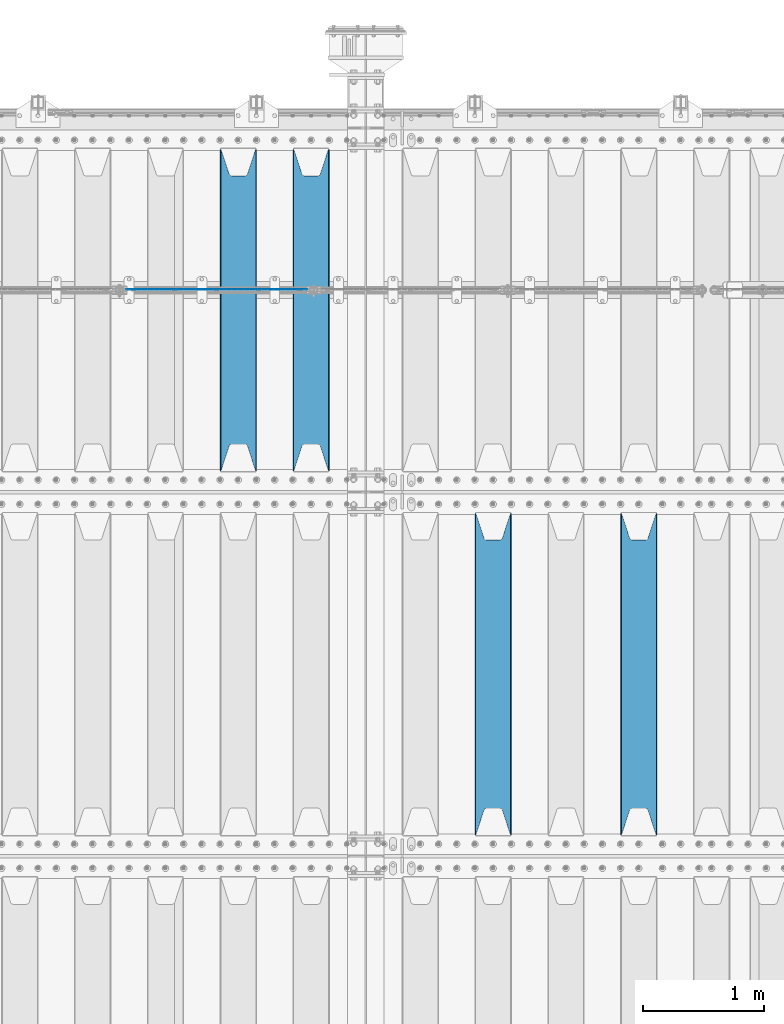
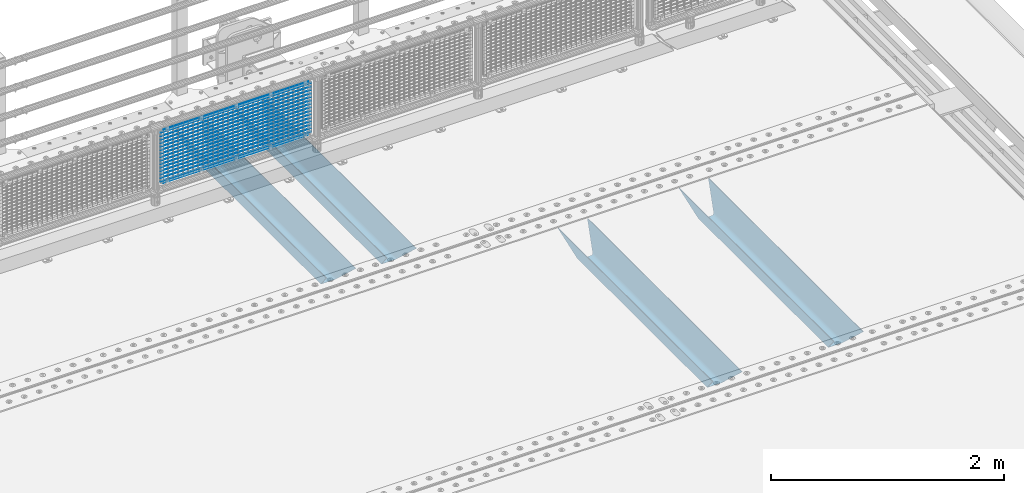
# One storey, part 125 of 257: 21 beams.
"""IFC2X3 building model written with IfcOpenShell, lengths in millimetres."""

from ifc_helpers import new_model, si_unit, frame, origin_with_axes, place, context, subcontext, project, spatial, faceted_brep, material, type_object, element, save


model = new_model("IFC2X3")

# Units and contexts
model_context = context("Model", 3, precision=1e-05, world=origin_with_axes())
body_context = subcontext(model_context, "Body", "Model", "MODEL_VIEW")
ifc_project = project(units=[si_unit("LENGTHUNIT", "METRE", prefix="MILLI"), si_unit("AREAUNIT", "SQUARE_METRE"), si_unit("VOLUMEUNIT", "CUBIC_METRE"), si_unit("MASSUNIT", "GRAM", prefix="KILO"), si_unit("TIMEUNIT", "SECOND"), si_unit("PLANEANGLEUNIT", "RADIAN"), si_unit("SOLIDANGLEUNIT", "STERADIAN"), si_unit("THERMODYNAMICTEMPERATUREUNIT", "DEGREE_CELSIUS"), si_unit("LUMINOUSINTENSITYUNIT", "LUMEN")], contexts=[model_context])

# Site, building, storey
site_placement = place(None, origin_with_axes())
site = spatial("IfcSite", under=ifc_project, at=site_placement, CompositionType="ELEMENT")
building_placement = place(site_placement, origin_with_axes())
building = spatial("IfcBuilding", under=site, at=building_placement, Name="Standard", CompositionType="ELEMENT")
storey_placement = place(building_placement, origin_with_axes())
storey = spatial("IfcBuildingStorey", under=building, at=storey_placement, Name="Undefined", CompositionType="ELEMENT", Elevation=0.0)

# Beams
ifc_material_1 = material(Name="STEEL/S355N")
beam_type_1 = type_object("IfcBeamType", PredefinedType="NOTDEFINED")
beam_1_placement = place(storey_placement, frame((56950.0, 6175.0, -115.0), z_axis=(0.0, 0.0, 1.0), x_axis=(0.0, 1.0, 0.0)))
element("IfcBeam", 1, at=beam_1_placement, inside=storey, type_object=beam_type_1, material=ifc_material_1, context=body_context, shape_type="Brep", body=[
    faceted_brep([(0.0, 150.0, 115.0), (0.0, 143.690000000002, 115.0), (2650.00000000297, 143.690000000002, 115.0), (2650.00000000297, 150.0, 115.0), (2650.00000000297, 142.059565218406, 110.0000000031), (2650.00000000297, 148.369565218403, 110.0000000031), (2441.90079219208, -80.1103600731149, -98.0992078077845), (2437.7588105432, -77.5672621345584, -102.241189456673), (2434.06523489746, -74.4080125315522, -105.934765102404), (2430.91086095089, -70.7102721255724, -109.089139048974), (2428.37322971128, -66.5649389910031, -111.626770288588), (2426.51472138055, -62.0739139532889, -113.485278619323), (2425.38102192091, -57.3475956567636, -114.618978078955), (2424.99999999987, -52.5021667386536, -115.0), (2424.99999999987, 52.5021667386536, -115.0), (2425.38102192091, 57.3475956567636, -114.618978078955), (2426.51472138055, 62.0739139532889, -113.485278619323), (2428.37322971128, 66.5649389910031, -111.626770288588), (2430.91086095089, 70.7102721255724, -109.089139048974), (2434.06523489746, 74.4080125315522, -105.934765102404), (2437.7588105432, 77.5672621345584, -102.241189456673), (2441.90079219208, 80.1103600731149, -98.0992078077846), (2446.38936140511, 81.9747917625791, -93.6106385947584), (2448.24948500409, 76.2713538057287, -91.7505149957729), (2444.62967112262, 74.76777986261, -95.3703288772456), (2441.28936334126, 72.7168944282894, -98.710636658607), (2438.31067330438, 70.1691124903809, -101.689326695487), (2435.76682334747, 67.1870637758839, -104.233176652398), (2433.72034654133, 63.8440531834931, -106.279653458539), (2432.22154950041, 60.2222587982324, -107.778450499454), (2431.30727574265, 56.4107117849126, -108.692724257221), (2430.99999999987, 52.5031078186876, -109.0), (2430.99999999987, -52.5031078186876, -109.0), (2431.30727574265, -56.4107117849126, -108.692724257221), (2432.22154950041, -60.2222587982324, -107.778450499454), (2433.72034654133, -63.8440531834931, -106.279653458539), (2435.76682334747, -67.1870637758839, -104.233176652398), (2438.31067330438, -70.1691124903809, -101.689326695487), (2441.28936334126, -72.7168944282894, -98.7106366586071), (2444.62967112262, -74.76777986261, -95.3703288772457), (2448.24948500409, -76.2713538057287, -91.7505149957729), (2650.00000000297, -142.059565218406, 110.0000000031), (2650.00000000297, -148.369565218403, 110.0000000031), (2446.38936140511, -81.9747917625791, -93.6106385947584), (2650.00000000297, -143.690000000002, 115.0), (2650.00000000297, -150.0, 115.0), (0.0, -143.690000000002, 115.0), (0.0, -150.0, 115.0), (0.0, -148.369565218258, 110.000000002662), (203.61063859742, -81.9747917625791, -93.6106385947584), (208.099207810447, -80.1103600731149, -98.0992078077845), (212.241189459335, -77.5672621345584, -102.241189456673), (215.934765105066, -74.4080125315522, -105.934765102404), (219.089139051636, -70.7102721255724, -109.089139048974), (221.626770291251, -66.5649389910031, -111.626770288588), (223.485278621985, -62.0739139532889, -113.485278619323), (224.618978081617, -57.3475956567636, -114.618978078955), (225.000000002662, -52.5021667386536, -115.0), (225.000000002662, 52.5021667386536, -115.0), (224.618978081617, 57.3475956567636, -114.618978078955), (223.485278621985, 62.0739139532889, -113.485278619323), (221.626770291251, 66.5649389910031, -111.626770288588), (219.089139051636, 70.7102721255724, -109.089139048974), (215.934765105066, 74.4080125315522, -105.934765102404), (212.241189459335, 77.5672621345584, -102.241189456673), (208.099207810447, 80.1103600731149, -98.0992078077846), (203.61063859742, 81.9747917625791, -93.6106385947584), (0.0, 148.369565218258, 110.000000002662), (0.0, 142.05956521826, 110.000000002662), (201.750514998435, 76.2713538057287, -91.7505149957729), (205.370328879908, 74.76777986261, -95.3703288772456), (208.710636661269, 72.7168944282894, -98.710636658607), (211.689326698149, 70.1691124903809, -101.689326695487), (214.233176655061, 67.1870637758839, -104.233176652398), (216.279653461201, 63.8440531834931, -106.279653458539), (217.778450502116, 60.2222587982324, -107.778450499454), (218.692724259884, 56.4107117849126, -108.692724257221), (219.000000002662, 52.5031078186876, -109.0), (219.000000002662, -52.5031078186876, -109.0), (218.692724259884, -56.4107117849126, -108.692724257221), (217.778450502116, -60.2222587982324, -107.778450499454), (216.279653461201, -63.8440531834931, -106.279653458539), (214.233176655061, -67.1870637758839, -104.233176652398), (211.689326698149, -70.1691124903809, -101.689326695487), (208.710636661269, -72.7168944282894, -98.7106366586071), (205.370328879908, -74.76777986261, -95.3703288772457), (201.750514998435, -76.2713538057287, -91.7505149957729), (0.0, -142.05956521826, 110.000000002662)], [[[0, 1, 2, 3]], [[3, 2, 4, 5]], [[6, 7, 8, 9, 10, 11, 12, 13, 14, 15, 16, 17, 18, 19, 20, 21, 22, 5, 4, 23, 24, 25, 26, 27, 28, 29, 30, 31, 32, 33, 34, 35, 36, 37, 38, 39, 40, 41, 42, 43]], [[44, 45, 42, 41]], [[46, 47, 45, 44]], [[43, 42, 45, 47, 48, 49]], [[6, 43, 49, 50]], [[7, 6, 50, 51]], [[8, 7, 51, 52]], [[9, 8, 52, 53]], [[10, 9, 53, 54]], [[11, 10, 54, 55]], [[12, 11, 55, 56]], [[13, 12, 56, 57]], [[14, 13, 57, 58]], [[15, 14, 58, 59]], [[16, 15, 59, 60]], [[17, 16, 60, 61]], [[18, 17, 61, 62]], [[19, 18, 62, 63]], [[20, 19, 63, 64]], [[21, 20, 64, 65]], [[22, 21, 65, 66]], [[0, 3, 5, 22, 66, 67]], [[1, 0, 67, 68]], [[23, 4, 2, 1, 68, 69]], [[24, 23, 69, 70]], [[25, 24, 70, 71]], [[26, 25, 71, 72]], [[27, 26, 72, 73]], [[28, 27, 73, 74]], [[29, 28, 74, 75]], [[30, 29, 75, 76]], [[31, 30, 76, 77]], [[32, 31, 77, 78]], [[33, 32, 78, 79]], [[34, 33, 79, 80]], [[35, 34, 80, 81]], [[36, 35, 81, 82]], [[37, 36, 82, 83]], [[38, 37, 83, 84]], [[39, 38, 84, 85]], [[40, 39, 85, 86]], [[46, 44, 41, 40, 86, 87]], [[47, 46, 87, 48]], [[86, 85, 84, 83, 82, 81, 80, 79, 78, 77, 76, 75, 74, 73, 72, 71, 70, 69, 68, 67, 66, 65, 64, 63, 62, 61, 60, 59, 58, 57, 56, 55, 54, 53, 52, 51, 50, 49, 48, 87]]]),
])
beam_2_placement = place(storey_placement, frame((55750.0, 6175.0, -115.0), z_axis=(0.0, 0.0, 1.0), x_axis=(0.0, 1.0, 0.0)))
element("IfcBeam", 2, at=beam_2_placement, inside=storey, type_object=beam_type_1, material=ifc_material_1, context=body_context, shape_type="Brep", body=[
    faceted_brep([(0.0, 150.0, 115.0), (0.0, 143.690000000002, 115.0), (2650.00000000297, 143.690000000002, 115.0), (2650.00000000297, 150.0, 115.0), (2650.00000000297, 142.059565218406, 110.0000000031), (2650.00000000297, 148.369565218403, 110.0000000031), (2441.90079219208, -80.1103600731149, -98.0992078077845), (2437.7588105432, -77.5672621345584, -102.241189456673), (2434.06523489746, -74.4080125315522, -105.934765102404), (2430.91086095089, -70.7102721255724, -109.089139048974), (2428.37322971128, -66.5649389910031, -111.626770288588), (2426.51472138055, -62.0739139532889, -113.485278619323), (2425.38102192091, -57.3475956567636, -114.618978078955), (2424.99999999987, -52.5021667386536, -115.0), (2424.99999999987, 52.5021667386536, -115.0), (2425.38102192091, 57.3475956567636, -114.618978078955), (2426.51472138055, 62.0739139532889, -113.485278619323), (2428.37322971128, 66.5649389910031, -111.626770288588), (2430.91086095089, 70.7102721255724, -109.089139048974), (2434.06523489746, 74.4080125315522, -105.934765102404), (2437.7588105432, 77.5672621345584, -102.241189456673), (2441.90079219208, 80.1103600731149, -98.0992078077846), (2446.38936140511, 81.9747917625791, -93.6106385947584), (2448.24948500409, 76.2713538057287, -91.7505149957729), (2444.62967112262, 74.76777986261, -95.3703288772456), (2441.28936334126, 72.7168944282894, -98.710636658607), (2438.31067330438, 70.1691124903809, -101.689326695487), (2435.76682334747, 67.1870637758839, -104.233176652398), (2433.72034654133, 63.8440531834931, -106.279653458539), (2432.22154950041, 60.2222587982324, -107.778450499454), (2431.30727574265, 56.4107117849126, -108.692724257221), (2430.99999999987, 52.5031078186876, -109.0), (2430.99999999987, -52.5031078186876, -109.0), (2431.30727574265, -56.4107117849126, -108.692724257221), (2432.22154950041, -60.2222587982324, -107.778450499454), (2433.72034654133, -63.8440531834931, -106.279653458539), (2435.76682334747, -67.1870637758839, -104.233176652398), (2438.31067330438, -70.1691124903809, -101.689326695487), (2441.28936334126, -72.7168944282894, -98.7106366586071), (2444.62967112262, -74.76777986261, -95.3703288772457), (2448.24948500409, -76.2713538057287, -91.7505149957729), (2650.00000000297, -142.059565218406, 110.0000000031), (2650.00000000297, -148.369565218403, 110.0000000031), (2446.38936140511, -81.9747917625791, -93.6106385947584), (2650.00000000297, -143.690000000002, 115.0), (2650.00000000297, -150.0, 115.0), (0.0, -143.690000000002, 115.0), (0.0, -150.0, 115.0), (0.0, -148.369565218258, 110.000000002662), (203.61063859742, -81.9747917625791, -93.6106385947584), (208.099207810447, -80.1103600731149, -98.0992078077845), (212.241189459335, -77.5672621345584, -102.241189456673), (215.934765105066, -74.4080125315522, -105.934765102404), (219.089139051636, -70.7102721255724, -109.089139048974), (221.626770291251, -66.5649389910031, -111.626770288588), (223.485278621985, -62.0739139532889, -113.485278619323), (224.618978081617, -57.3475956567636, -114.618978078955), (225.000000002662, -52.5021667386536, -115.0), (225.000000002662, 52.5021667386536, -115.0), (224.618978081617, 57.3475956567636, -114.618978078955), (223.485278621985, 62.0739139532889, -113.485278619323), (221.626770291251, 66.5649389910031, -111.626770288588), (219.089139051636, 70.7102721255724, -109.089139048974), (215.934765105066, 74.4080125315522, -105.934765102404), (212.241189459335, 77.5672621345584, -102.241189456673), (208.099207810447, 80.1103600731149, -98.0992078077846), (203.61063859742, 81.9747917625791, -93.6106385947584), (0.0, 148.369565218258, 110.000000002662), (0.0, 142.05956521826, 110.000000002662), (201.750514998435, 76.2713538057287, -91.7505149957729), (205.370328879908, 74.76777986261, -95.3703288772456), (208.710636661269, 72.7168944282894, -98.710636658607), (211.689326698149, 70.1691124903809, -101.689326695487), (214.233176655061, 67.1870637758839, -104.233176652398), (216.279653461201, 63.8440531834931, -106.279653458539), (217.778450502116, 60.2222587982324, -107.778450499454), (218.692724259884, 56.4107117849126, -108.692724257221), (219.000000002662, 52.5031078186876, -109.0), (219.000000002662, -52.5031078186876, -109.0), (218.692724259884, -56.4107117849126, -108.692724257221), (217.778450502116, -60.2222587982324, -107.778450499454), (216.279653461201, -63.8440531834931, -106.279653458539), (214.233176655061, -67.1870637758839, -104.233176652398), (211.689326698149, -70.1691124903809, -101.689326695487), (208.710636661269, -72.7168944282894, -98.7106366586071), (205.370328879908, -74.76777986261, -95.3703288772457), (201.750514998435, -76.2713538057287, -91.7505149957729), (0.0, -142.05956521826, 110.000000002662)], [[[0, 1, 2, 3]], [[3, 2, 4, 5]], [[6, 7, 8, 9, 10, 11, 12, 13, 14, 15, 16, 17, 18, 19, 20, 21, 22, 5, 4, 23, 24, 25, 26, 27, 28, 29, 30, 31, 32, 33, 34, 35, 36, 37, 38, 39, 40, 41, 42, 43]], [[44, 45, 42, 41]], [[46, 47, 45, 44]], [[43, 42, 45, 47, 48, 49]], [[6, 43, 49, 50]], [[7, 6, 50, 51]], [[8, 7, 51, 52]], [[9, 8, 52, 53]], [[10, 9, 53, 54]], [[11, 10, 54, 55]], [[12, 11, 55, 56]], [[13, 12, 56, 57]], [[14, 13, 57, 58]], [[15, 14, 58, 59]], [[16, 15, 59, 60]], [[17, 16, 60, 61]], [[18, 17, 61, 62]], [[19, 18, 62, 63]], [[20, 19, 63, 64]], [[21, 20, 64, 65]], [[22, 21, 65, 66]], [[0, 3, 5, 22, 66, 67]], [[1, 0, 67, 68]], [[23, 4, 2, 1, 68, 69]], [[24, 23, 69, 70]], [[25, 24, 70, 71]], [[26, 25, 71, 72]], [[27, 26, 72, 73]], [[28, 27, 73, 74]], [[29, 28, 74, 75]], [[30, 29, 75, 76]], [[31, 30, 76, 77]], [[32, 31, 77, 78]], [[33, 32, 78, 79]], [[34, 33, 79, 80]], [[35, 34, 80, 81]], [[36, 35, 81, 82]], [[37, 36, 82, 83]], [[38, 37, 83, 84]], [[39, 38, 84, 85]], [[40, 39, 85, 86]], [[46, 44, 41, 40, 86, 87]], [[47, 46, 87, 48]], [[86, 85, 84, 83, 82, 81, 80, 79, 78, 77, 76, 75, 74, 73, 72, 71, 70, 69, 68, 67, 66, 65, 64, 63, 62, 61, 60, 59, 58, 57, 56, 55, 54, 53, 52, 51, 50, 49, 48, 87]]]),
])
beam_3_placement = place(storey_placement, frame((54250.0, 9175.0, -115.0), z_axis=(0.0, 0.0, 1.0), x_axis=(0.0, 1.0, 0.0)))
element("IfcBeam", 3, at=beam_3_placement, inside=storey, type_object=beam_type_1, material=ifc_material_1, context=body_context, shape_type="Brep", body=[
    faceted_brep([(0.0, 150.0, 115.0), (0.0, 143.690000000002, 115.0), (2650.00000000297, 143.690000000002, 115.0), (2650.00000000297, 150.0, 115.0), (2650.00000000297, 142.059565218406, 110.0000000031), (2650.00000000297, 148.369565218403, 110.0000000031), (2441.90079219208, -80.1103600731149, -98.0992078077845), (2437.7588105432, -77.5672621345584, -102.241189456673), (2434.06523489746, -74.4080125315522, -105.934765102404), (2430.91086095089, -70.7102721255724, -109.089139048974), (2428.37322971128, -66.5649389910031, -111.626770288588), (2426.51472138055, -62.0739139532889, -113.485278619323), (2425.38102192091, -57.3475956567636, -114.618978078955), (2424.99999999987, -52.5021667386536, -115.0), (2424.99999999987, 52.5021667386536, -115.0), (2425.38102192091, 57.3475956567636, -114.618978078955), (2426.51472138055, 62.0739139532889, -113.485278619323), (2428.37322971128, 66.5649389910031, -111.626770288588), (2430.91086095089, 70.7102721255724, -109.089139048974), (2434.06523489746, 74.4080125315522, -105.934765102404), (2437.7588105432, 77.5672621345584, -102.241189456673), (2441.90079219208, 80.1103600731149, -98.0992078077846), (2446.38936140511, 81.9747917625791, -93.6106385947584), (2448.24948500409, 76.2713538057287, -91.7505149957729), (2444.62967112262, 74.76777986261, -95.3703288772456), (2441.28936334126, 72.7168944282894, -98.710636658607), (2438.31067330438, 70.1691124903809, -101.689326695487), (2435.76682334747, 67.1870637758839, -104.233176652398), (2433.72034654133, 63.8440531834931, -106.279653458539), (2432.22154950041, 60.2222587982324, -107.778450499454), (2431.30727574265, 56.4107117849126, -108.692724257221), (2430.99999999987, 52.5031078186876, -109.0), (2430.99999999987, -52.5031078186876, -109.0), (2431.30727574265, -56.4107117849126, -108.692724257221), (2432.22154950041, -60.2222587982324, -107.778450499454), (2433.72034654133, -63.8440531834931, -106.279653458539), (2435.76682334747, -67.1870637758839, -104.233176652398), (2438.31067330438, -70.1691124903809, -101.689326695487), (2441.28936334126, -72.7168944282894, -98.7106366586071), (2444.62967112262, -74.76777986261, -95.3703288772457), (2448.24948500409, -76.2713538057287, -91.7505149957729), (2650.00000000297, -142.059565218406, 110.0000000031), (2650.00000000297, -148.369565218403, 110.0000000031), (2446.38936140511, -81.9747917625791, -93.6106385947584), (2650.00000000297, -143.690000000002, 115.0), (2650.00000000297, -150.0, 115.0), (0.0, -143.690000000002, 115.0), (0.0, -150.0, 115.0), (0.0, -148.369565218258, 110.000000002662), (203.61063859742, -81.9747917625791, -93.6106385947584), (208.099207810447, -80.1103600731149, -98.0992078077845), (212.241189459335, -77.5672621345584, -102.241189456673), (215.934765105066, -74.4080125315522, -105.934765102404), (219.089139051636, -70.7102721255724, -109.089139048974), (221.626770291251, -66.5649389910031, -111.626770288588), (223.485278621985, -62.0739139532889, -113.485278619323), (224.618978081617, -57.3475956567636, -114.618978078955), (225.000000002662, -52.5021667386536, -115.0), (225.000000002662, 52.5021667386536, -115.0), (224.618978081617, 57.3475956567636, -114.618978078955), (223.485278621985, 62.0739139532889, -113.485278619323), (221.626770291251, 66.5649389910031, -111.626770288588), (219.089139051636, 70.7102721255724, -109.089139048974), (215.934765105066, 74.4080125315522, -105.934765102404), (212.241189459335, 77.5672621345584, -102.241189456673), (208.099207810447, 80.1103600731149, -98.0992078077846), (203.61063859742, 81.9747917625791, -93.6106385947584), (0.0, 148.369565218258, 110.000000002662), (0.0, 142.05956521826, 110.000000002662), (201.750514998435, 76.2713538057287, -91.7505149957729), (205.370328879908, 74.76777986261, -95.3703288772456), (208.710636661269, 72.7168944282894, -98.710636658607), (211.689326698149, 70.1691124903809, -101.689326695487), (214.233176655061, 67.1870637758839, -104.233176652398), (216.279653461201, 63.8440531834931, -106.279653458539), (217.778450502116, 60.2222587982324, -107.778450499454), (218.692724259884, 56.4107117849126, -108.692724257221), (219.000000002662, 52.5031078186876, -109.0), (219.000000002662, -52.5031078186876, -109.0), (218.692724259884, -56.4107117849126, -108.692724257221), (217.778450502116, -60.2222587982324, -107.778450499454), (216.279653461201, -63.8440531834931, -106.279653458539), (214.233176655061, -67.1870637758839, -104.233176652398), (211.689326698149, -70.1691124903809, -101.689326695487), (208.710636661269, -72.7168944282894, -98.7106366586071), (205.370328879908, -74.76777986261, -95.3703288772457), (201.750514998435, -76.2713538057287, -91.7505149957729), (0.0, -142.05956521826, 110.000000002662)], [[[0, 1, 2, 3]], [[3, 2, 4, 5]], [[6, 7, 8, 9, 10, 11, 12, 13, 14, 15, 16, 17, 18, 19, 20, 21, 22, 5, 4, 23, 24, 25, 26, 27, 28, 29, 30, 31, 32, 33, 34, 35, 36, 37, 38, 39, 40, 41, 42, 43]], [[44, 45, 42, 41]], [[46, 47, 45, 44]], [[43, 42, 45, 47, 48, 49]], [[6, 43, 49, 50]], [[7, 6, 50, 51]], [[8, 7, 51, 52]], [[9, 8, 52, 53]], [[10, 9, 53, 54]], [[11, 10, 54, 55]], [[12, 11, 55, 56]], [[13, 12, 56, 57]], [[14, 13, 57, 58]], [[15, 14, 58, 59]], [[16, 15, 59, 60]], [[17, 16, 60, 61]], [[18, 17, 61, 62]], [[19, 18, 62, 63]], [[20, 19, 63, 64]], [[21, 20, 64, 65]], [[22, 21, 65, 66]], [[0, 3, 5, 22, 66, 67]], [[1, 0, 67, 68]], [[23, 4, 2, 1, 68, 69]], [[24, 23, 69, 70]], [[25, 24, 70, 71]], [[26, 25, 71, 72]], [[27, 26, 72, 73]], [[28, 27, 73, 74]], [[29, 28, 74, 75]], [[30, 29, 75, 76]], [[31, 30, 76, 77]], [[32, 31, 77, 78]], [[33, 32, 78, 79]], [[34, 33, 79, 80]], [[35, 34, 80, 81]], [[36, 35, 81, 82]], [[37, 36, 82, 83]], [[38, 37, 83, 84]], [[39, 38, 84, 85]], [[40, 39, 85, 86]], [[46, 44, 41, 40, 86, 87]], [[47, 46, 87, 48]], [[86, 85, 84, 83, 82, 81, 80, 79, 78, 77, 76, 75, 74, 73, 72, 71, 70, 69, 68, 67, 66, 65, 64, 63, 62, 61, 60, 59, 58, 57, 56, 55, 54, 53, 52, 51, 50, 49, 48, 87]]]),
])
beam_4_placement = place(storey_placement, frame((53650.0, 9175.0, -115.0), z_axis=(0.0, 0.0, 1.0), x_axis=(0.0, 1.0, 0.0)))
element("IfcBeam", 4, at=beam_4_placement, inside=storey, type_object=beam_type_1, material=ifc_material_1, context=body_context, shape_type="Brep", body=[
    faceted_brep([(0.0, 150.0, 115.0), (0.0, 143.690000000002, 115.0), (2650.00000000297, 143.690000000002, 115.0), (2650.00000000297, 150.0, 115.0), (2650.00000000297, 142.059565218406, 110.0000000031), (2650.00000000297, 148.369565218403, 110.0000000031), (2441.90079219208, -80.1103600731149, -98.0992078077845), (2437.7588105432, -77.5672621345584, -102.241189456673), (2434.06523489746, -74.4080125315522, -105.934765102404), (2430.91086095089, -70.7102721255724, -109.089139048974), (2428.37322971128, -66.5649389910031, -111.626770288588), (2426.51472138055, -62.0739139532889, -113.485278619323), (2425.38102192091, -57.3475956567636, -114.618978078955), (2424.99999999987, -52.5021667386536, -115.0), (2424.99999999987, 52.5021667386536, -115.0), (2425.38102192091, 57.3475956567636, -114.618978078955), (2426.51472138055, 62.0739139532889, -113.485278619323), (2428.37322971128, 66.5649389910031, -111.626770288588), (2430.91086095089, 70.7102721255724, -109.089139048974), (2434.06523489746, 74.4080125315522, -105.934765102404), (2437.7588105432, 77.5672621345584, -102.241189456673), (2441.90079219208, 80.1103600731149, -98.0992078077846), (2446.38936140511, 81.9747917625791, -93.6106385947584), (2448.24948500409, 76.2713538057287, -91.7505149957729), (2444.62967112262, 74.76777986261, -95.3703288772456), (2441.28936334126, 72.7168944282894, -98.710636658607), (2438.31067330438, 70.1691124903809, -101.689326695487), (2435.76682334747, 67.1870637758839, -104.233176652398), (2433.72034654133, 63.8440531834931, -106.279653458539), (2432.22154950041, 60.2222587982324, -107.778450499454), (2431.30727574265, 56.4107117849126, -108.692724257221), (2430.99999999987, 52.5031078186876, -109.0), (2430.99999999987, -52.5031078186876, -109.0), (2431.30727574265, -56.4107117849126, -108.692724257221), (2432.22154950041, -60.2222587982324, -107.778450499454), (2433.72034654133, -63.8440531834931, -106.279653458539), (2435.76682334747, -67.1870637758839, -104.233176652398), (2438.31067330438, -70.1691124903809, -101.689326695487), (2441.28936334126, -72.7168944282894, -98.7106366586071), (2444.62967112262, -74.76777986261, -95.3703288772457), (2448.24948500409, -76.2713538057287, -91.7505149957729), (2650.00000000297, -142.059565218406, 110.0000000031), (2650.00000000297, -148.369565218403, 110.0000000031), (2446.38936140511, -81.9747917625791, -93.6106385947584), (2650.00000000297, -143.690000000002, 115.0), (2650.00000000297, -150.0, 115.0), (0.0, -143.690000000002, 115.0), (0.0, -150.0, 115.0), (0.0, -148.369565218258, 110.000000002662), (203.61063859742, -81.9747917625791, -93.6106385947584), (208.099207810447, -80.1103600731149, -98.0992078077845), (212.241189459335, -77.5672621345584, -102.241189456673), (215.934765105066, -74.4080125315522, -105.934765102404), (219.089139051636, -70.7102721255724, -109.089139048974), (221.626770291251, -66.5649389910031, -111.626770288588), (223.485278621985, -62.0739139532889, -113.485278619323), (224.618978081617, -57.3475956567636, -114.618978078955), (225.000000002662, -52.5021667386536, -115.0), (225.000000002662, 52.5021667386536, -115.0), (224.618978081617, 57.3475956567636, -114.618978078955), (223.485278621985, 62.0739139532889, -113.485278619323), (221.626770291251, 66.5649389910031, -111.626770288588), (219.089139051636, 70.7102721255724, -109.089139048974), (215.934765105066, 74.4080125315522, -105.934765102404), (212.241189459335, 77.5672621345584, -102.241189456673), (208.099207810447, 80.1103600731149, -98.0992078077846), (203.61063859742, 81.9747917625791, -93.6106385947584), (0.0, 148.369565218258, 110.000000002662), (0.0, 142.05956521826, 110.000000002662), (201.750514998435, 76.2713538057287, -91.7505149957729), (205.370328879908, 74.76777986261, -95.3703288772456), (208.710636661269, 72.7168944282894, -98.710636658607), (211.689326698149, 70.1691124903809, -101.689326695487), (214.233176655061, 67.1870637758839, -104.233176652398), (216.279653461201, 63.8440531834931, -106.279653458539), (217.778450502116, 60.2222587982324, -107.778450499454), (218.692724259884, 56.4107117849126, -108.692724257221), (219.000000002662, 52.5031078186876, -109.0), (219.000000002662, -52.5031078186876, -109.0), (218.692724259884, -56.4107117849126, -108.692724257221), (217.778450502116, -60.2222587982324, -107.778450499454), (216.279653461201, -63.8440531834931, -106.279653458539), (214.233176655061, -67.1870637758839, -104.233176652398), (211.689326698149, -70.1691124903809, -101.689326695487), (208.710636661269, -72.7168944282894, -98.7106366586071), (205.370328879908, -74.76777986261, -95.3703288772457), (201.750514998435, -76.2713538057287, -91.7505149957729), (0.0, -142.05956521826, 110.000000002662)], [[[0, 1, 2, 3]], [[3, 2, 4, 5]], [[6, 7, 8, 9, 10, 11, 12, 13, 14, 15, 16, 17, 18, 19, 20, 21, 22, 5, 4, 23, 24, 25, 26, 27, 28, 29, 30, 31, 32, 33, 34, 35, 36, 37, 38, 39, 40, 41, 42, 43]], [[44, 45, 42, 41]], [[46, 47, 45, 44]], [[43, 42, 45, 47, 48, 49]], [[6, 43, 49, 50]], [[7, 6, 50, 51]], [[8, 7, 51, 52]], [[9, 8, 52, 53]], [[10, 9, 53, 54]], [[11, 10, 54, 55]], [[12, 11, 55, 56]], [[13, 12, 56, 57]], [[14, 13, 57, 58]], [[15, 14, 58, 59]], [[16, 15, 59, 60]], [[17, 16, 60, 61]], [[18, 17, 61, 62]], [[19, 18, 62, 63]], [[20, 19, 63, 64]], [[21, 20, 64, 65]], [[22, 21, 65, 66]], [[0, 3, 5, 22, 66, 67]], [[1, 0, 67, 68]], [[23, 4, 2, 1, 68, 69]], [[24, 23, 69, 70]], [[25, 24, 70, 71]], [[26, 25, 71, 72]], [[27, 26, 72, 73]], [[28, 27, 73, 74]], [[29, 28, 74, 75]], [[30, 29, 75, 76]], [[31, 30, 76, 77]], [[32, 31, 77, 78]], [[33, 32, 78, 79]], [[34, 33, 79, 80]], [[35, 34, 80, 81]], [[36, 35, 81, 82]], [[37, 36, 82, 83]], [[38, 37, 83, 84]], [[39, 38, 84, 85]], [[40, 39, 85, 86]], [[46, 44, 41, 40, 86, 87]], [[47, 46, 87, 48]], [[86, 85, 84, 83, 82, 81, 80, 79, 78, 77, 76, 75, 74, 73, 72, 71, 70, 69, 68, 67, 66, 65, 64, 63, 62, 61, 60, 59, 58, 57, 56, 55, 54, 53, 52, 51, 50, 49, 48, 87]]]),
])
ifc_material_2 = material(Name="Misc_Undefined")
beam_type_2 = type_object("IfcBeamType", Name="D3", PredefinedType="NOTDEFINED")
for number, where, z_axis, x_axis in (
    (5, (52726.0, 10670.5, 851.597000000004), (0.0, 0.0, 1.0), (1.0, 0.0, 0.0)),
    (6, (52726.0, 10670.5, 669.452000000004), (0.0, 0.0, 1.0), (1.0, 0.0, 0.0)),
    (7, (52726.0, 10670.5, 523.736000000004), (0.0, 0.0, 1.0), (1.0, 0.0, 0.0)),
    (8, (52726.0, 10670.5, 487.307000000004), (0.0, 0.0, 1.0), (1.0, 0.0, 0.0)),
    (9, (52726.0, 10670.5, 705.881000000004), (0.0, 0.0, 1.0), (1.0, 0.0, 0.0)),
    (10, (52726.0, 10670.5, 596.594000000004), (0.0, 0.0, 1.0), (1.0, 0.0, 0.0)),
    (11, (52726.0, 10670.5, 450.878000000004), (0.0, 0.0, 1.0), (1.0, 0.0, 0.0)),
    (12, (52726.0, 10670.5, 815.168000000004), (0.0, 0.0, 1.0), (1.0, 0.0, 0.0)),
    (13, (52726.0, 10670.5, 888.026000000004), (0.0, 0.0, 1.0), (1.0, 0.0, 0.0)),
    (14, (52726.0, 10670.5, 778.739000000004), (0.0, 0.0, 1.0), (1.0, 0.0, 0.0)),
    (15, (52726.0, 10670.5, 742.310000000004), (0.0, 0.0, 1.0), (1.0, 0.0, 0.0)),
    (16, (52726.0, 10670.5, 633.023000000004), (0.0, 0.0, 1.0), (1.0, 0.0, 0.0)),
    (17, (52726.0, 10670.5, 560.165000000004), (0.0, 0.0, 1.0), (1.0, 0.0, 0.0)),
    (18, (52726.0, 10670.5, 414.449000000004), (0.0, 0.0, 1.0), (1.0, 0.0, 0.0)),
):
    element("IfcBeam", number, at=place(storey_placement, frame(where, z_axis=z_axis, x_axis=x_axis)), inside=storey, type_object=beam_type_2, material=ifc_material_2, ObjectType="D3", context=body_context, shape_type="Brep", body=[
        faceted_brep([(0.0, -1.5, -5.6843418860808e-14), (0.0, -0.750000000001819, -1.29903810567669), (1490.0, -0.75, -1.29903810567669), (1490.0, -1.5, 0.0), (7.27595761418343e-12, 0.749999999998181, -1.29903810567669), (1490.0, 0.75, -1.29903810567669), (0.0, 1.5, -5.6843418860808e-14), (1490.0, 1.5, 0.0), (7.27595761418343e-12, 0.749999999998181, 1.29903810567669), (1490.0, 0.75, 1.29903810567669), (0.0, -0.750000000001819, 1.29903810567669), (1490.0, -0.75, 1.29903810567669)], [[[0, 1, 2, 3]], [[1, 4, 5, 2]], [[4, 6, 7, 5]], [[6, 8, 9, 7]], [[8, 10, 11, 9]], [[10, 0, 3, 11]], [[5, 7, 9, 11, 3, 2]], [[10, 8, 6, 4, 1, 0]]]),
    ])
beam_5_placement = place(storey_placement, frame((52751.0, 10670.5, 353.020000000004), z_axis=(0.0, 0.0, 1.0), x_axis=(1.0, 0.0, 0.0)))
element("IfcBeam", 19, at=beam_5_placement, inside=storey, type_object=beam_type_2, material=ifc_material_2, ObjectType="D3", context=body_context, shape_type="Brep", body=[
    faceted_brep([(0.0, -1.5, -5.6843418860808e-14), (0.0, -0.750000000001819, -1.29903810567669), (1440.0, -0.75, -1.29903810567669), (1440.0, -1.5, 0.0), (7.27595761418343e-12, 0.749999999998181, -1.29903810567669), (1440.0, 0.75, -1.29903810567663), (0.0, 1.5, -5.6843418860808e-14), (1440.0, 1.5, 0.0), (7.27595761418343e-12, 0.749999999998181, 1.29903810567669), (1440.0, 0.75, 1.29903810567669), (0.0, -0.750000000001819, 1.29903810567669), (1440.0, -0.75, 1.29903810567669)], [[[0, 1, 2, 3]], [[1, 4, 5, 2]], [[4, 6, 7, 5]], [[6, 8, 9, 7]], [[8, 10, 11, 9]], [[10, 0, 3, 11]], [[5, 7, 9, 11, 3, 2]], [[10, 8, 6, 4, 1, 0]]]),
])
beam_6_placement = place(storey_placement, frame((52726.0, 10670.5, 378.020000000004), z_axis=(0.0, 0.0, 1.0), x_axis=(1.0, 0.0, 0.0)))
element("IfcBeam", 20, at=beam_6_placement, inside=storey, type_object=beam_type_2, material=ifc_material_2, ObjectType="D3", context=body_context, shape_type="Brep", body=[
    faceted_brep([(0.0, -1.5, -5.6843418860808e-14), (0.0, -0.750000000001819, -1.29903810567669), (1490.0, -0.75, -1.29903810567669), (1490.0, -1.5, 0.0), (7.27595761418343e-12, 0.749999999998181, -1.29903810567669), (1490.0, 0.75, -1.29903810567669), (0.0, 1.5, -5.6843418860808e-14), (1490.0, 1.5, 0.0), (7.27595761418343e-12, 0.749999999998181, 1.29903810567669), (1490.0, 0.75, 1.29903810567669), (0.0, -0.750000000001819, 1.29903810567669), (1490.0, -0.75, 1.29903810567669)], [[[0, 1, 2, 3]], [[1, 4, 5, 2]], [[4, 6, 7, 5]], [[6, 8, 9, 7]], [[8, 10, 11, 9]], [[10, 0, 3, 11]], [[5, 7, 9, 11, 3, 2]], [[10, 8, 6, 4, 1, 0]]]),
])
beam_7_placement = place(storey_placement, frame((52751.0, 10670.5, 913.020000000004), z_axis=(0.0, 0.0, 1.0), x_axis=(1.0, 0.0, 0.0)))
element("IfcBeam", 21, at=beam_7_placement, inside=storey, type_object=beam_type_2, material=ifc_material_2, ObjectType="D3", context=body_context, shape_type="Brep", body=[
    faceted_brep([(0.0, -1.5, -5.6843418860808e-14), (0.0, -0.750000000001819, -1.29903810567669), (1440.0, -0.75, -1.29903810567669), (1440.0, -1.5, 0.0), (7.27595761418343e-12, 0.749999999998181, -1.29903810567669), (1440.0, 0.75, -1.29903810567663), (0.0, 1.5, -5.6843418860808e-14), (1440.0, 1.5, 0.0), (7.27595761418343e-12, 0.749999999998181, 1.29903810567669), (1440.0, 0.75, 1.29903810567669), (0.0, -0.750000000001819, 1.29903810567669), (1440.0, -0.75, 1.29903810567669)], [[[0, 1, 2, 3]], [[1, 4, 5, 2]], [[4, 6, 7, 5]], [[6, 8, 9, 7]], [[8, 10, 11, 9]], [[10, 0, 3, 11]], [[5, 7, 9, 11, 3, 2]], [[10, 8, 6, 4, 1, 0]]]),
])

save(model, "model.ifc")
